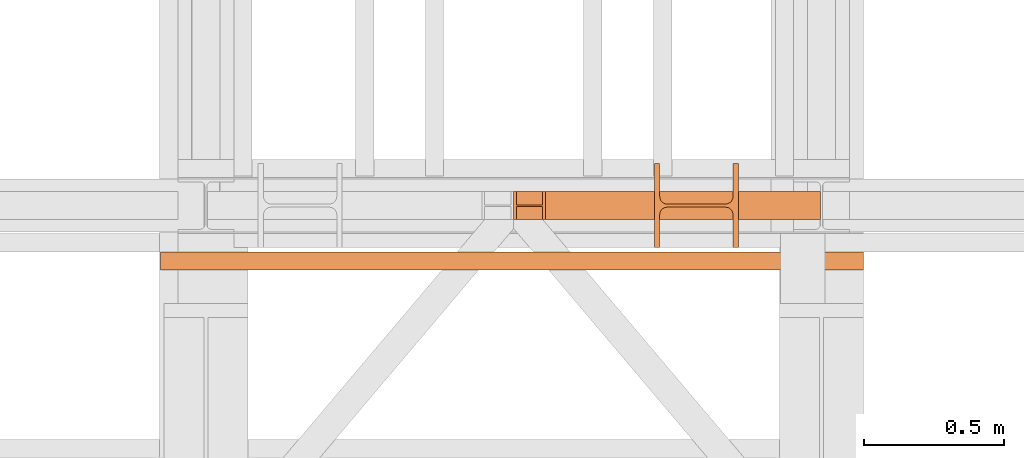
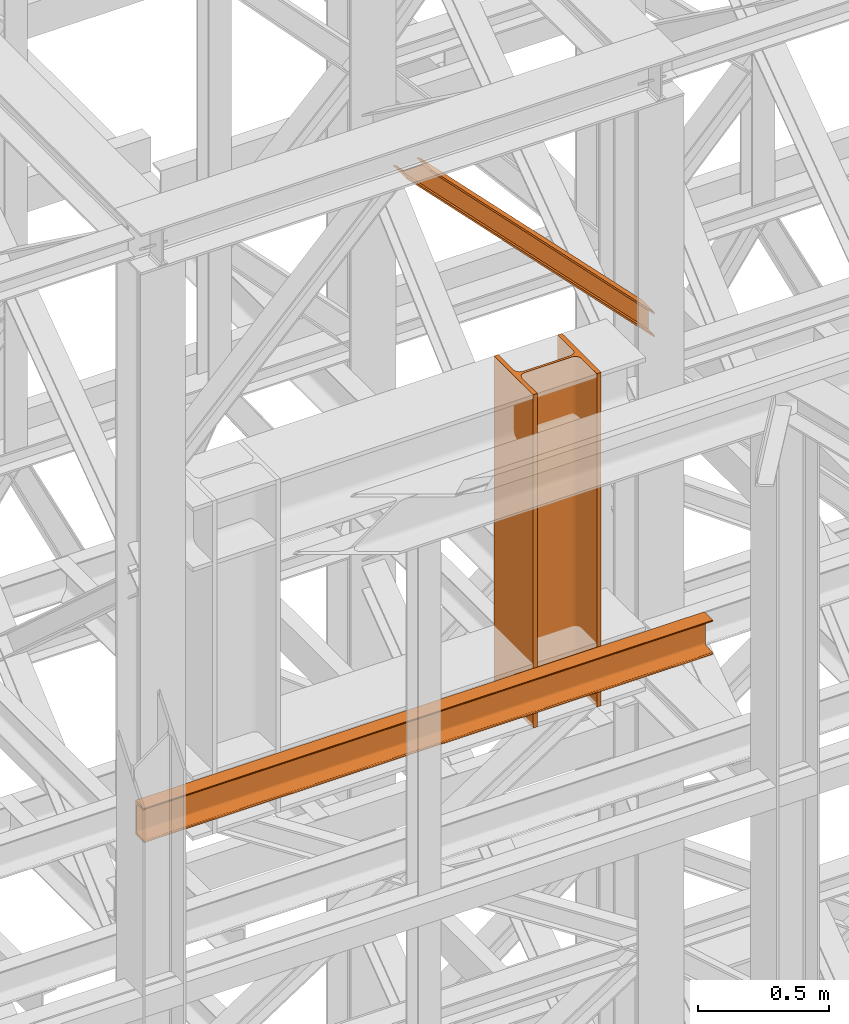
# One storey, part 150 of 208: 3 proxies.
"""IFC2X3 building model written with IfcOpenShell, lengths in millimetres."""

from ifc_helpers import new_model, entity, si_unit, converted_unit, frame, origin, origin_with_axes, place, context, subcontext, project, spatial, faceted_brep, element, save


model = new_model("IFC2X3")

# Units and contexts
model_context = context("Model", 3, precision=1e-05, world=origin())
plan_context = context("Plan", 3, precision=1e-05, world=origin())
body_context = subcontext(model_context, "Body", "Model", "MODEL_VIEW")
ifc_project = project(units=[si_unit("LENGTHUNIT", "METRE", prefix="MILLI"), converted_unit("PLANEANGLEUNIT", "DEGREE", entity("IfcPlaneAngleMeasure", 0.0174532925199433), si_unit("PLANEANGLEUNIT", "RADIAN"), dimensions=[0, 0, 0, 0, 0, 0, 0]), si_unit("AREAUNIT", "SQUARE_METRE"), si_unit("VOLUMEUNIT", "CUBIC_METRE")], contexts=[model_context, plan_context])

# Building, storey
building_placement = place(None, origin())
building = spatial("IfcBuilding", under=ifc_project, at=building_placement, CompositionType="COMPLEX")
storey_placement = place(building_placement, origin_with_axes())
storey = spatial("IfcBuildingStorey", under=building, at=storey_placement, Name="Geschoss", CompositionType="ELEMENT")

# Proxies
proxy_1_placement = place(storey_placement, frame((4896.25496703855, -16112.48734116498, 9568.99005869381), z_axis=(0.0, 0.0, 1.0), x_axis=(1.0, 0.0, 0.0)))
element("IfcBuildingElementProxy", 1, at=proxy_1_placement, inside=storey, context=body_context, shape_type="Brep", body=[
    faceted_brep([(0.01000000000021828, 300.0100000000002, 1556.01), (0.01000000000021828, 300.0100000000002, 0.01000000000021828), (19.01000000000022, 300.0100000000002, 0.01000000000021828), (19.01000000000022, 300.0100000000002, 1556.01), (19.01000000000022, 300.0100000000002, 1556.01), (19.01000000000022, 300.0100000000002, 0.01000000000021828), (19.01000000000022, 182.5100000000002, 0.01000000000021828), (19.01000000000022, 182.5100000000002, 1556.01), (19.01000000000022, 182.5100000000002, 1556.01), (19.01000000000022, 182.5100000000002, 0.01000000000021828), (19.93008181249388, 175.5219092192219, 0.01000000000021828), (19.93008181249388, 175.5219092192219, 1556.01), (19.93008181249388, 175.5219092192219, 1556.01), (19.93008181249388, 175.5219092192219, 0.01000000000021828), (22.62738661818912, 169.0100393754565, 0.01000000000021828), (22.62738661818912, 169.0100393754565, 1556.01), (22.62738661818912, 169.0100393754565, 1556.01), (22.62738661818912, 169.0100393754565, 0.01000000000021828), (26.91811690796385, 163.4181169079584, 0.01000000000021828), (26.91811690796203, 163.4181169079584, 1556.01), (26.91811690796203, 163.4181169079584, 1556.01), (26.91811690796385, 163.4181169079584, 0.01000000000021828), (32.51003937545829, 159.1273866181855, 0.01000000000021828), (32.51003937545829, 159.1273866181855, 1556.01), (32.51003937545829, 159.1273866181855, 1556.01), (32.51003937545829, 159.1273866181855, 0.01000000000021828), (39.02190921922374, 156.4300818124921, 0.01000000000021828), (39.02190921922374, 156.4300818124921, 1556.01), (39.02190921922374, 156.4300818124921, 1556.01), (39.02190921922374, 156.4300818124921, 0.01000000000021828), (46.01000000000022, 155.5100000000002, 0.01000000000021828), (46.01000000000022, 155.5100000000002, 1556.01), (46.01000000000022, 155.5100000000002, 1556.01), (46.01000000000022, 155.5100000000002, 0.01000000000021828), (254.0100000000002, 155.5100000000002, 0.01000000000021828), (254.0100000000002, 155.5100000000002, 1556.01), (254.0100000000002, 155.5100000000002, 1556.01), (254.0100000000002, 155.5100000000002, 0.01000000000021828), (262.3534305458597, 156.8315660577409, 0.01000000000021828), (262.3534305458597, 156.8315660577409, 1556.01), (262.3534305458597, 156.8315660577409, 1556.01), (262.3534305458597, 156.8315660577409, 0.01000000000021828), (269.8801750658022, 160.6665745365954, 0.01000000000021828), (269.8801750658004, 160.6665745365954, 1556.01), (269.8801750658004, 160.6665745365954, 1556.01), (269.8801750658022, 160.6665745365954, 0.01000000000021828), (275.8534254634014, 166.6398249341964, 0.01000000000021828), (275.8534254634014, 166.6398249341964, 1556.01), (275.8534254634014, 166.6398249341964, 1556.01), (275.8534254634014, 166.6398249341964, 0.01000000000021828), (279.6884339422595, 174.1665694541352, 0.01000000000021828), (279.6884339422595, 174.1665694541352, 1556.01), (279.6884339422595, 174.1665694541352, 1556.01), (279.6884339422595, 174.1665694541352, 0.01000000000021828), (281.0100000000002, 182.5100000000002, 0.01000000000021828), (281.0100000000002, 182.5100000000002, 1556.01), (281.0100000000002, 182.5100000000002, 1556.01), (281.0100000000002, 182.5100000000002, 0.01000000000021828), (281.0100000000002, 300.0100000000002, 0.01000000000021828), (281.0100000000002, 300.0100000000002, 1556.01), (281.0100000000002, 300.0100000000002, 1556.01), (281.0100000000002, 300.0100000000002, 0.01000000000021828), (300.0100000000002, 300.0100000000002, 0.01000000000021828), (300.0100000000002, 300.0100000000002, 1556.01), (300.0100000000002, 300.0100000000002, 1556.01), (300.0100000000002, 300.0100000000002, 0.01000000000021828), (300.0100000000002, 0.01000000000021828, 0.01000000000021828), (300.0100000000002, 0.01000000000021828, 1556.01), (300.0100000000002, 0.01000000000021828, 1556.01), (300.0100000000002, 0.01000000000021828, 0.01000000000021828), (281.0100000000002, 0.01000000000021828, 0.01000000000021828), (281.0100000000002, 0.01000000000021828, 1556.01), (281.0100000000002, 0.01000000000021828, 1556.01), (281.0100000000002, 0.01000000000021828, 0.01000000000021828), (281.0100000000002, 117.5100000000002, 0.01000000000021828), (281.0100000000002, 117.5100000000002, 1556.01), (281.0100000000002, 117.5100000000002, 1556.01), (281.0100000000002, 117.5100000000002, 0.01000000000021828), (279.6884339422595, 125.8534305458579, 0.01000000000021828), (279.6884339422595, 125.8534305458579, 1556.01), (279.6884339422595, 125.8534305458579, 1556.01), (279.6884339422595, 125.8534305458579, 0.01000000000021828), (275.8534254634014, 133.3801750658004, 0.01000000000021828), (275.8534254634014, 133.3801750658004, 1556.01), (275.8534254634014, 133.3801750658004, 1556.01), (275.8534254634014, 133.3801750658004, 0.01000000000021828), (269.8801750658022, 139.3534254633978, 0.01000000000021828), (269.8801750658004, 139.3534254633978, 1556.01), (269.8801750658004, 139.3534254633978, 1556.01), (269.8801750658022, 139.3534254633978, 0.01000000000021828), (262.3534305458616, 143.1884339422595, 0.01000000000021828), (262.3534305458616, 143.1884339422595, 1556.01), (262.3534305458616, 143.1884339422595, 1556.01), (262.3534305458616, 143.1884339422595, 0.01000000000021828), (254.0100000000002, 144.5100000000002, 0.01000000000021828), (254.0100000000002, 144.5100000000002, 1556.01), (254.0100000000002, 144.5100000000002, 1556.01), (254.0100000000002, 144.5100000000002, 0.01000000000021828), (46.01000000000022, 144.5100000000002, 0.01000000000021828), (46.01000000000022, 144.5100000000002, 1556.01), (46.01000000000022, 144.5100000000002, 1556.01), (46.01000000000022, 144.5100000000002, 0.01000000000021828), (37.66656945413888, 143.1884339422595, 0.01000000000021828), (37.66656945413888, 143.1884339422595, 1556.01), (37.66656945413888, 143.1884339422595, 1556.01), (37.66656945413888, 143.1884339422595, 0.01000000000021828), (30.13982493419826, 139.3534254633978, 0.01000000000021828), (30.13982493419826, 139.3534254633978, 1556.01), (30.13982493419826, 139.3534254633978, 1556.01), (30.13982493419826, 139.3534254633978, 0.01000000000021828), (24.16657453659718, 133.3801750658004, 0.01000000000021828), (24.16657453659718, 133.3801750658004, 1556.01), (24.16657453659718, 133.3801750658004, 1556.01), (24.16657453659718, 133.3801750658004, 0.01000000000021828), (20.33156605774093, 125.8534305458579, 0.01000000000021828), (20.33156605774093, 125.8534305458579, 1556.01), (20.33156605774093, 125.8534305458579, 1556.01), (20.33156605774093, 125.8534305458579, 0.01000000000021828), (19.01000000000022, 117.5100000000002, 0.01000000000021828), (19.01000000000022, 117.5100000000002, 1556.01), (19.01000000000022, 117.5100000000002, 1556.01), (19.01000000000022, 117.5100000000002, 0.01000000000021828), (19.01000000000022, 0.01000000000021828, 0.01000000000021828), (19.01000000000022, 0.01000000000021828, 1556.01), (19.01000000000022, 0.01000000000021828, 1556.01), (19.01000000000022, 0.01000000000021828, 0.01000000000021828), (0.01000000000021828, 0.01000000000021828, 0.01000000000021828), (0.01000000000021828, 0.01000000000021828, 1556.01), (0.01000000000021828, 0.01000000000021828, 1556.01), (0.01000000000021828, 0.01000000000021828, 0.01000000000021828), (0.01000000000021828, 300.0100000000002, 0.01000000000021828), (0.01000000000021828, 300.0100000000002, 1556.01), (0.01000000000021828, 300.0100000000002, 1556.01), (19.01000000000022, 300.0100000000002, 1556.01), (19.01000000000022, 182.5100000000002, 1556.01), (19.93008181249388, 175.5219092192219, 1556.01), (22.62738661818912, 169.0100393754565, 1556.01), (26.91811690796203, 163.4181169079584, 1556.01), (32.51003937545829, 159.1273866181855, 1556.01), (39.02190921922374, 156.4300818124921, 1556.01), (46.01000000000022, 155.5100000000002, 1556.01), (254.0100000000002, 155.5100000000002, 1556.01), (262.3534305458597, 156.8315660577409, 1556.01), (269.8801750658004, 160.6665745365954, 1556.01), (275.8534254634014, 166.6398249341964, 1556.01), (279.6884339422595, 174.1665694541352, 1556.01), (281.0100000000002, 182.5100000000002, 1556.01), (281.0100000000002, 300.0100000000002, 1556.01), (300.0100000000002, 300.0100000000002, 1556.01), (300.0100000000002, 0.01000000000021828, 1556.01), (281.0100000000002, 0.01000000000021828, 1556.01), (281.0100000000002, 117.5100000000002, 1556.01), (279.6884339422595, 125.8534305458579, 1556.01), (275.8534254634014, 133.3801750658004, 1556.01), (269.8801750658004, 139.3534254633978, 1556.01), (262.3534305458616, 143.1884339422595, 1556.01), (254.0100000000002, 144.5100000000002, 1556.01), (46.01000000000022, 144.5100000000002, 1556.01), (37.66656945413888, 143.1884339422595, 1556.01), (30.13982493419826, 139.3534254633978, 1556.01), (24.16657453659718, 133.3801750658004, 1556.01), (20.33156605774093, 125.8534305458579, 1556.01), (19.01000000000022, 117.5100000000002, 1556.01), (19.01000000000022, 0.01000000000021828, 1556.01), (0.01000000000021828, 0.01000000000021828, 1556.01), (0.01000000000021828, 300.0100000000002, 0.01000000000021828), (0.01000000000021828, 0.01000000000021828, 0.01000000000021828), (19.01000000000022, 0.01000000000021828, 0.01000000000021828), (19.01000000000022, 117.5100000000002, 0.01000000000021828), (20.33156605774093, 125.8534305458579, 0.01000000000021828), (24.16657453659718, 133.3801750658004, 0.01000000000021828), (30.13982493419826, 139.3534254633978, 0.01000000000021828), (37.66656945413888, 143.1884339422595, 0.01000000000021828), (46.01000000000022, 144.5100000000002, 0.01000000000021828), (254.0100000000002, 144.5100000000002, 0.01000000000021828), (262.3534305458616, 143.1884339422595, 0.01000000000021828), (269.8801750658022, 139.3534254633978, 0.01000000000021828), (275.8534254634014, 133.3801750658004, 0.01000000000021828), (279.6884339422595, 125.8534305458579, 0.01000000000021828), (281.0100000000002, 117.5100000000002, 0.01000000000021828), (281.0100000000002, 0.01000000000021828, 0.01000000000021828), (300.0100000000002, 0.01000000000021828, 0.01000000000021828), (300.0100000000002, 300.0100000000002, 0.01000000000021828), (281.0100000000002, 300.0100000000002, 0.01000000000021828), (281.0100000000002, 182.5100000000002, 0.01000000000021828), (279.6884339422595, 174.1665694541352, 0.01000000000021828), (275.8534254634014, 166.6398249341964, 0.01000000000021828), (269.8801750658022, 160.6665745365954, 0.01000000000021828), (262.3534305458597, 156.8315660577409, 0.01000000000021828), (254.0100000000002, 155.5100000000002, 0.01000000000021828), (46.01000000000022, 155.5100000000002, 0.01000000000021828), (39.02190921922374, 156.4300818124921, 0.01000000000021828), (32.51003937545829, 159.1273866181855, 0.01000000000021828), (26.91811690796385, 163.4181169079584, 0.01000000000021828), (22.62738661818912, 169.0100393754565, 0.01000000000021828), (19.93008181249388, 175.5219092192219, 0.01000000000021828), (19.01000000000022, 182.5100000000002, 0.01000000000021828), (19.01000000000022, 300.0100000000002, 0.01000000000021828)], [[[0, 1, 2, 3]], [[4, 5, 6, 7]], [[8, 9, 10, 11]], [[12, 13, 14, 15]], [[16, 17, 18, 19]], [[20, 21, 22, 23]], [[24, 25, 26, 27]], [[28, 29, 30, 31]], [[32, 33, 34, 35]], [[36, 37, 38, 39]], [[40, 41, 42, 43]], [[44, 45, 46, 47]], [[48, 49, 50, 51]], [[52, 53, 54, 55]], [[56, 57, 58, 59]], [[60, 61, 62, 63]], [[64, 65, 66, 67]], [[68, 69, 70, 71]], [[72, 73, 74, 75]], [[76, 77, 78, 79]], [[80, 81, 82, 83]], [[84, 85, 86, 87]], [[88, 89, 90, 91]], [[92, 93, 94, 95]], [[96, 97, 98, 99]], [[100, 101, 102, 103]], [[104, 105, 106, 107]], [[108, 109, 110, 111]], [[112, 113, 114, 115]], [[116, 117, 118, 119]], [[120, 121, 122, 123]], [[124, 125, 126, 127]], [[128, 129, 130, 131]], [[132, 133, 134, 135, 136, 137, 138, 139, 140, 141, 142, 143, 144, 145, 146, 147, 148, 149, 150, 151, 152, 153, 154, 155, 156, 157, 158, 159, 160, 161, 162, 163, 164]], [[165, 166, 167, 168, 169, 170, 171, 172, 173, 174, 175, 176, 177, 178, 179, 180, 181, 182, 183, 184, 185, 186, 187, 188, 189, 190, 191, 192, 193, 194, 195, 196, 197]]], orient=[[False], [False], [False], [False], [False], [False], [False], [False], [False], [False], [False], [False], [False], [False], [False], [False], [False], [False], [False], [False], [False], [False], [False], [False], [False], [False], [False], [False], [False], [False], [False], [False], [False], [False], [False]]),
])
proxy_2_placement = place(storey_placement, frame((4393.254968528665, -16012.57439031789, 11124.99005869381), z_axis=(0.0, 0.0, 1.0), x_axis=(1.0, 0.0, 0.0)))
element("IfcBuildingElementProxy", 2, at=proxy_2_placement, inside=storey, context=body_context, shape_type="Brep", body=[
    faceted_brep([(9.44942509107841, 0.01000000000021828, 1125.010000000004), (1096.759999932946, 0.01000000000021828, 9.692565058685432), (1096.759999932946, 0.01000000000021828, 0.01000000000203727), (0.01000000000021828, 0.01000000000021828, 1125.010000000002), (0.01000000000021828, 0.01000000000021828, 1125.010000000002), (1096.759999932946, 0.01000000000021828, 0.01000000000203727), (1096.759999932946, 100.0100000000002, 0.01000000000021828), (0.01000000000021828, 100.0100000000002, 1125.010000000002), (0.01000000000021828, 100.0100000000002, 1125.010000000002), (1096.759999932946, 100.0100000000002, 0.01000000000021828), (1096.759999932946, 100.0100000000002, 9.692565058685432), (9.44942509107932, 100.0100000000002, 1125.010000000004), (9.44942509107932, 100.0100000000002, 1125.010000000004), (1096.759999932946, 100.0100000000002, 9.692565058685432), (1096.759999932946, 52.51000000000022, 9.692565058685432), (9.44942509107932, 52.51000000000022, 1125.010000000004), (9.44942509107932, 52.51000000000022, 1125.010000000004), (1096.759999932946, 52.51000000000022, 9.692565058685432), (1096.759999932944, 52.51000000000022, 106.5182156455558), (103.843676001884, 52.51000000000022, 1125.010000000002), (103.843676001884, 52.51000000000022, 1125.010000000002), (1096.759999932944, 52.51000000000022, 106.5182156455558), (1096.759999932946, 100.0100000000002, 106.5182156455558), (103.8436760018822, 100.0100000000002, 1125.010000000002), (103.8436760018822, 100.0100000000002, 1125.010000000002), (1096.759999932946, 100.0100000000002, 106.5182156455558), (1096.759999932944, 100.0100000000002, 116.2007807042428), (113.283101092964, 100.0100000000002, 1125.010000000002), (113.283101092964, 100.0100000000002, 1125.010000000002), (1096.759999932944, 100.0100000000002, 116.2007807042428), (1096.759999932946, 0.01000000000021828, 116.2007807042428), (113.2831010929649, 0.01000000000021828, 1125.010000000002), (113.2831010929649, 0.01000000000021828, 1125.010000000002), (1096.759999932946, 0.01000000000021828, 116.2007807042428), (1096.759999932946, 0.01000000000021828, 106.5182156455558), (103.843676001884, 0.01000000000021828, 1125.010000000002), (103.843676001884, 0.01000000000021828, 1125.010000000002), (1096.759999932946, 0.01000000000021828, 106.5182156455558), (1096.759999932946, 47.51000000000022, 106.5182156455539), (103.8436760018822, 47.51000000000022, 1125.010000000002), (103.8436760018822, 47.51000000000022, 1125.010000000002), (1096.759999932946, 47.51000000000022, 106.5182156455539), (1096.759999932946, 47.51000000000022, 9.692565058685432), (9.44942509107932, 47.51000000000022, 1125.010000000004), (9.44942509107932, 47.51000000000022, 1125.010000000004), (1096.759999932946, 47.51000000000022, 9.692565058685432), (1096.759999932946, 0.01000000000021828, 9.692565058685432), (9.44942509107841, 0.01000000000021828, 1125.010000000004), (1096.759999932946, 0.01000000000021828, 9.692565058685432), (1096.759999932946, 47.51000000000022, 9.692565058685432), (1096.759999932946, 47.51000000000022, 106.5182156455539), (1096.759999932946, 0.01000000000021828, 106.5182156455558), (1096.759999932946, 0.01000000000021828, 116.2007807042428), (1096.759999932944, 100.0100000000002, 116.2007807042428), (1096.759999932946, 100.0100000000002, 106.5182156455558), (1096.759999932944, 52.51000000000022, 106.5182156455558), (1096.759999932946, 52.51000000000022, 9.692565058685432), (1096.759999932946, 100.0100000000002, 9.692565058685432), (1096.759999932946, 100.0100000000002, 0.01000000000021828), (1096.759999932946, 0.01000000000021828, 0.01000000000203727), (0.01000000000021828, 0.01000000000021828, 1125.010000000002), (0.01000000000021828, 100.0100000000002, 1125.010000000002), (9.44942509107932, 100.0100000000002, 1125.010000000004), (9.44942509107932, 52.51000000000022, 1125.010000000004), (103.843676001884, 52.51000000000022, 1125.010000000002), (103.8436760018822, 100.0100000000002, 1125.010000000002), (113.283101092964, 100.0100000000002, 1125.010000000002), (113.2831010929649, 0.01000000000021828, 1125.010000000002), (103.843676001884, 0.01000000000021828, 1125.010000000002), (103.8436760018822, 47.51000000000022, 1125.010000000002), (9.44942509107932, 47.51000000000022, 1125.010000000004), (9.44942509107841, 0.01000000000021828, 1125.010000000004)], [[[0, 1, 2, 3]], [[4, 5, 6, 7]], [[8, 9, 10, 11]], [[12, 13, 14, 15]], [[16, 17, 18, 19]], [[20, 21, 22, 23]], [[24, 25, 26, 27]], [[28, 29, 30, 31]], [[32, 33, 34, 35]], [[36, 37, 38, 39]], [[40, 41, 42, 43]], [[44, 45, 46, 47]], [[48, 49, 50, 51, 52, 53, 54, 55, 56, 57, 58, 59]], [[60, 61, 62, 63, 64, 65, 66, 67, 68, 69, 70, 71]]], orient=[[False], [False], [False], [False], [False], [False], [False], [False], [False], [False], [False], [False], [False], [False]]),
])
proxy_3_placement = place(storey_placement, frame((3131.36685311597, -16192.574391808, 9699.99), z_axis=(0.0, 0.0, 1.0), x_axis=(1.0, 0.0, 0.0)))
element("IfcBuildingElementProxy", 3, at=proxy_3_placement, inside=storey, context=body_context, shape_type="Brep", body=[
    faceted_brep([(0.01000000000021828, 0.01000000000021828, 0.01000000000021828), (0.01000000000021828, 0.01000000000021828, 3.132428070246533), (2511.898121373161, 0.01000000000021828, 3.132428070246533), (2511.898121373161, 0.01000000000021828, 0.01000000000021828), (0.01000000000021828, 0.01000000000021828, 3.132428070246533), (0.01000000000021828, 0.2527365771729819, 4.748288908171162), (2511.898121373161, 0.2527365771729819, 4.748288908171162), (2511.898121373161, 0.01000000000021828, 3.132428070246533), (0.01000000000021828, 0.2527365771729819, 4.748288908171162), (0.01000000000021828, 0.9594677141431021, 6.221534443444398), (2511.898121373161, 0.9594677141431021, 6.221534443444398), (2511.898121373161, 0.2527365771729819, 4.748288908171162), (0.01000000000021828, 0.9594677141431021, 6.221534443444398), (0.01000000000021828, 2.067848361530196, 7.422126703873801), (2511.898121373161, 2.067848361530196, 7.422126703873801), (2511.898121373161, 0.9594677141431021, 6.221534443444398), (0.01000000000021828, 2.067848361530196, 7.422126703873801), (0.01000000000021828, 3.4800435885154, 8.244091391710754), (2511.898121373161, 3.4800435885154, 8.244091391710754), (2511.898121373161, 2.067848361530196, 7.422126703873801), (0.01000000000021828, 3.4800435885154, 8.244091391710754), (0.01000000000021828, 5.071401277444238, 8.614912102195376), (2511.898121373161, 5.071401277444238, 8.614912102195376), (2511.898121373161, 3.4800435885154, 8.244091391710754), (0.01000000000021828, 5.071401277444238, 8.614912102195376), (0.01000000000021828, 47.84732483397056, 12.0369859867169), (2511.898121373161, 47.84732483397056, 12.0369859867169), (2511.898121373161, 5.071401277444238, 8.614912102195376), (0.01000000000021828, 47.84732483397056, 12.0369859867169), (0.01000000000021828, 50.88537133101636, 12.74491643400506), (2511.898121373161, 50.88537133101636, 12.74491643400506), (2511.898121373161, 47.84732483397056, 12.0369859867169), (0.01000000000021828, 50.88537133101636, 12.74491643400506), (0.01000000000021828, 53.58138040071208, 14.31412174714933), (2511.898121373161, 53.5813804007139, 14.31412174714933), (2511.898121373161, 50.88537133101636, 12.74491643400506), (0.01000000000021828, 53.58138040071208, 14.31412174714933), (0.01000000000021828, 55.69737981845174, 16.60616151705835), (2511.898121373161, 55.69737981845356, 16.60616151705835), (2511.898121373161, 53.5813804007139, 14.31412174714933), (0.01000000000021828, 55.69737981845174, 16.60616151705835), (0.01000000000021828, 57.04659380721387, 19.41872117530875), (2511.898121373161, 57.04659380721387, 19.41872117530875), (2511.898121373161, 55.69737981845356, 16.60616151705835), (0.01000000000021828, 57.04659380721387, 19.41872117530875), (0.01000000000021828, 57.51000000000022, 22.50354641134618), (2511.898121373161, 57.51000000000022, 22.50354641134618), (2511.898121373161, 57.04659380721387, 19.41872117530875), (0.01000000000021828, 57.51000000000022, 22.50354641134618), (0.01000000000021828, 57.51000000000022, 137.5164535886524), (2511.898121373161, 57.51000000000022, 137.5164535886524), (2511.898121373161, 57.51000000000022, 22.50354641134618), (0.01000000000021828, 57.51000000000022, 137.5164535886524), (0.01000000000021828, 57.04659380721387, 140.6012788246917), (2511.898121373161, 57.04659380721387, 140.6012788246917), (2511.898121373161, 57.51000000000022, 137.5164535886524), (0.01000000000021828, 57.04659380721387, 140.6012788246917), (0.01000000000021828, 55.69737981845174, 143.4138384829403), (2511.898121373161, 55.69737981845356, 143.4138384829403), (2511.898121373161, 57.04659380721387, 140.6012788246917), (0.01000000000021828, 55.69737981845174, 143.4138384829403), (0.01000000000021828, 53.58138040071208, 145.7058782528493), (2511.898121373161, 53.5813804007139, 145.7058782528493), (2511.898121373161, 55.69737981845356, 143.4138384829403), (0.01000000000021828, 53.58138040071208, 145.7058782528493), (0.01000000000021828, 50.88537133101636, 147.2750835659936), (2511.898121373161, 50.88537133101636, 147.2750835659936), (2511.898121373161, 53.5813804007139, 145.7058782528493), (0.01000000000021828, 50.88537133101636, 147.2750835659936), (0.01000000000021828, 47.84732483397056, 147.9830140132817), (2511.898121373161, 47.84732483397056, 147.9830140132817), (2511.898121373161, 50.88537133101636, 147.2750835659936), (0.01000000000021828, 47.84732483397056, 147.9830140132817), (0.01000000000021828, 5.071401277444238, 151.4050878978032), (2511.898121373161, 5.071401277444238, 151.4050878978032), (2511.898121373161, 47.84732483397056, 147.9830140132817), (0.01000000000021828, 5.071401277444238, 151.4050878978032), (0.01000000000021828, 3.4800435885154, 151.7759086082879), (2511.898121373161, 3.4800435885154, 151.7759086082879), (2511.898121373161, 5.071401277444238, 151.4050878978032), (0.01000000000021828, 3.4800435885154, 151.7759086082879), (0.01000000000021828, 2.067848361530196, 152.5978732961248), (2511.898121373161, 2.067848361530196, 152.5978732961248), (2511.898121373161, 3.4800435885154, 151.7759086082879), (0.01000000000021828, 2.067848361530196, 152.5978732961248), (0.01000000000021828, 0.9594677141431021, 153.7984655565542), (2511.898121373161, 0.9594677141431021, 153.7984655565542), (2511.898121373161, 2.067848361530196, 152.5978732961248), (0.01000000000021828, 0.9594677141431021, 153.7984655565542), (0.01000000000021828, 0.2527365771729819, 155.2717110918275), (2511.898121373161, 0.2527365771729819, 155.2717110918275), (2511.898121373161, 0.9594677141431021, 153.7984655565542), (0.01000000000021828, 0.2527365771729819, 155.2717110918275), (0.01000000000021828, 0.01000000000021828, 156.8875719297521), (2511.898121373161, 0.01000000000021828, 156.8875719297521), (2511.898121373161, 0.2527365771729819, 155.2717110918275), (0.01000000000021828, 0.01000000000021828, 156.8875719297521), (0.01000000000021828, 0.01000000000021828, 160.0100000000002), (2511.898121373161, 0.01000000000021828, 160.0100000000002), (2511.898121373161, 0.01000000000021828, 156.8875719297521), (0.01000000000021828, 0.01000000000021828, 160.0100000000002), (0.01000000000021828, 65.01000000000022, 160.0100000000002), (2511.898121373161, 65.01000000000022, 160.0100000000002), (2511.898121373161, 0.01000000000021828, 160.0100000000002), (0.01000000000021828, 65.01000000000022, 160.0100000000002), (0.01000000000021828, 65.01000000000022, 0.01000000000021828), (2511.898121373161, 65.01000000000022, 0.01000000000021828), (2511.898121373161, 65.01000000000022, 160.0100000000002), (0.01000000000021828, 65.01000000000022, 0.01000000000021828), (0.01000000000021828, 0.01000000000021828, 0.01000000000021828), (2511.898121373161, 0.01000000000021828, 0.01000000000021828), (2511.898121373161, 65.01000000000022, 0.01000000000021828), (0.01000000000021828, 0.01000000000021828, 0.01000000000021828), (0.01000000000021828, 65.01000000000022, 0.01000000000021828), (0.01000000000021828, 65.01000000000022, 160.0100000000002), (0.01000000000021828, 0.01000000000021828, 160.0100000000002), (0.01000000000021828, 0.01000000000021828, 156.8875719297521), (0.01000000000021828, 0.2527365771729819, 155.2717110918275), (0.01000000000021828, 0.9594677141431021, 153.7984655565542), (0.01000000000021828, 2.067848361530196, 152.5978732961248), (0.01000000000021828, 3.4800435885154, 151.7759086082879), (0.01000000000021828, 5.071401277444238, 151.4050878978032), (0.01000000000021828, 47.84732483397056, 147.9830140132817), (0.01000000000021828, 50.88537133101636, 147.2750835659936), (0.01000000000021828, 53.58138040071208, 145.7058782528493), (0.01000000000021828, 55.69737981845174, 143.4138384829403), (0.01000000000021828, 57.04659380721387, 140.6012788246917), (0.01000000000021828, 57.51000000000022, 137.5164535886524), (0.01000000000021828, 57.51000000000022, 22.50354641134618), (0.01000000000021828, 57.04659380721387, 19.41872117530875), (0.01000000000021828, 55.69737981845174, 16.60616151705835), (0.01000000000021828, 53.58138040071208, 14.31412174714933), (0.01000000000021828, 50.88537133101636, 12.74491643400506), (0.01000000000021828, 47.84732483397056, 12.0369859867169), (0.01000000000021828, 5.071401277444238, 8.614912102195376), (0.01000000000021828, 3.4800435885154, 8.244091391710754), (0.01000000000021828, 2.067848361530196, 7.422126703873801), (0.01000000000021828, 0.9594677141431021, 6.221534443444398), (0.01000000000021828, 0.2527365771729819, 4.748288908171162), (0.01000000000021828, 0.01000000000021828, 3.132428070246533), (2511.898121373161, 0.01000000000021828, 0.01000000000021828), (2511.898121373161, 0.01000000000021828, 3.132428070246533), (2511.898121373161, 0.2527365771729819, 4.748288908171162), (2511.898121373161, 0.9594677141431021, 6.221534443444398), (2511.898121373161, 2.067848361530196, 7.422126703873801), (2511.898121373161, 3.4800435885154, 8.244091391710754), (2511.898121373161, 5.071401277444238, 8.614912102195376), (2511.898121373161, 47.84732483397056, 12.0369859867169), (2511.898121373161, 50.88537133101636, 12.74491643400506), (2511.898121373161, 53.5813804007139, 14.31412174714933), (2511.898121373161, 55.69737981845356, 16.60616151705835), (2511.898121373161, 57.04659380721387, 19.41872117530875), (2511.898121373161, 57.51000000000022, 22.50354641134618), (2511.898121373161, 57.51000000000022, 137.5164535886524), (2511.898121373161, 57.04659380721387, 140.6012788246917), (2511.898121373161, 55.69737981845356, 143.4138384829403), (2511.898121373161, 53.5813804007139, 145.7058782528493), (2511.898121373161, 50.88537133101636, 147.2750835659936), (2511.898121373161, 47.84732483397056, 147.9830140132817), (2511.898121373161, 5.071401277444238, 151.4050878978032), (2511.898121373161, 3.4800435885154, 151.7759086082879), (2511.898121373161, 2.067848361530196, 152.5978732961248), (2511.898121373161, 0.9594677141431021, 153.7984655565542), (2511.898121373161, 0.2527365771729819, 155.2717110918275), (2511.898121373161, 0.01000000000021828, 156.8875719297521), (2511.898121373161, 0.01000000000021828, 160.0100000000002), (2511.898121373161, 65.01000000000022, 160.0100000000002), (2511.898121373161, 65.01000000000022, 0.01000000000021828)], [[[0, 1, 2, 3]], [[4, 5, 6, 7]], [[8, 9, 10, 11]], [[12, 13, 14, 15]], [[16, 17, 18, 19]], [[20, 21, 22, 23]], [[24, 25, 26, 27]], [[28, 29, 30, 31]], [[32, 33, 34, 35]], [[36, 37, 38, 39]], [[40, 41, 42, 43]], [[44, 45, 46, 47]], [[48, 49, 50, 51]], [[52, 53, 54, 55]], [[56, 57, 58, 59]], [[60, 61, 62, 63]], [[64, 65, 66, 67]], [[68, 69, 70, 71]], [[72, 73, 74, 75]], [[76, 77, 78, 79]], [[80, 81, 82, 83]], [[84, 85, 86, 87]], [[88, 89, 90, 91]], [[92, 93, 94, 95]], [[96, 97, 98, 99]], [[100, 101, 102, 103]], [[104, 105, 106, 107]], [[108, 109, 110, 111]], [[112, 113, 114, 115, 116, 117, 118, 119, 120, 121, 122, 123, 124, 125, 126, 127, 128, 129, 130, 131, 132, 133, 134, 135, 136, 137, 138, 139]], [[140, 141, 142, 143, 144, 145, 146, 147, 148, 149, 150, 151, 152, 153, 154, 155, 156, 157, 158, 159, 160, 161, 162, 163, 164, 165, 166, 167]]], orient=[[False], [False], [False], [False], [False], [False], [False], [False], [False], [False], [False], [False], [False], [False], [False], [False], [False], [False], [False], [False], [False], [False], [False], [False], [False], [False], [False], [False], [False], [False]]),
])

save(model, "model.ifc")
